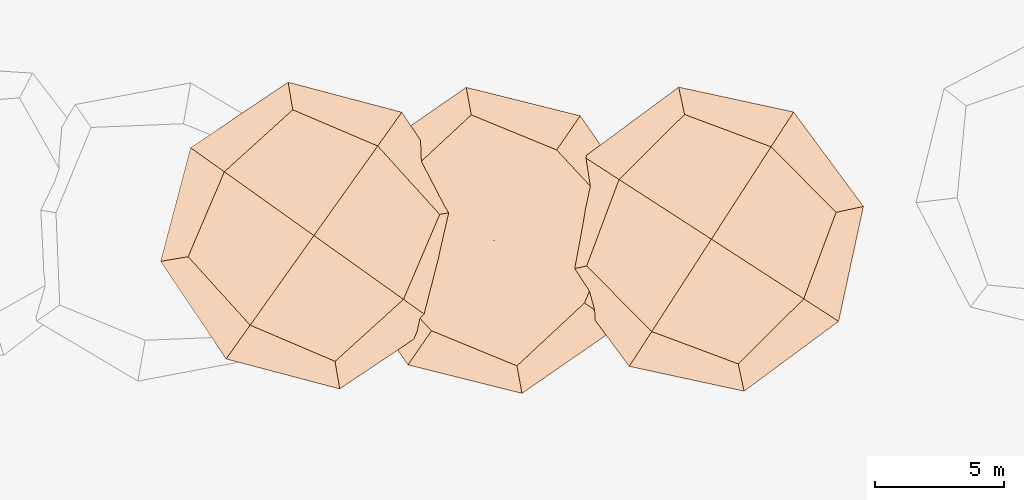
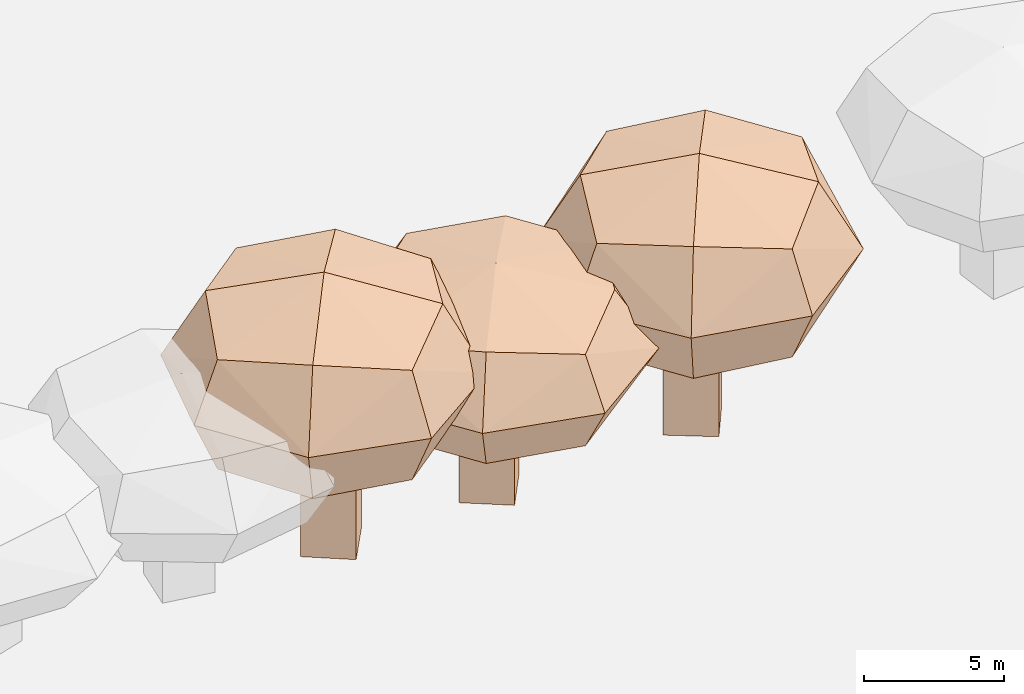
# Not in any storey, part 15 of 92: 3 geographic elements.
"""IFC4 model written with IfcOpenShell, lengths in metres."""

from ifc_helpers import new_model, si_unit, origin_with_axes, place, context, subcontext, project, spatial, triangles, material, element, save


model = new_model("IFC4")

# Units and contexts
model_context = context("Model", 3, precision=1e-05, world=origin_with_axes())
body_context = subcontext(model_context, "Body", "Model", "MODEL_VIEW")
ifc_project = project(units=[si_unit("VOLUMEUNIT", "CUBIC_METRE"), si_unit("LENGTHUNIT", "METRE"), si_unit("AREAUNIT", "SQUARE_METRE")], contexts=[model_context])

# Site
site_placement = place(None, origin_with_axes())
site = spatial("IfcSite", under=ifc_project, at=site_placement)

# Geographic elements
ifc_material = material(Name="tree")
geographic_element_1_placement = place(site_placement, origin_with_axes())
element("IfcGeographicElement", 1, at=geographic_element_1_placement, inside=site, material=ifc_material, Name="cw_instances_tree_206", context=body_context, shape_type="Tessellation", body=[
    triangles([(22.09761152949541, -637.1712850246641, 5.7020930998837915), (22.09761152949541, -637.1712850246641, 5.7020930998837915), (22.09761152949541, -637.1712850246641, 5.7020930998837915), (22.09761152949541, -637.1712850246641, 0.0), (22.09761152949541, -637.1712850246641, 0.0), (22.09761152949541, -637.1712850246641, 0.0), (23.235551606121536, -635.5265685196068, 5.7020930998837915), (23.235551606121536, -635.5265685196068, 5.7020930998837915), (23.235551606121536, -635.5265685196068, 5.7020930998837915), (23.235551606121536, -635.5265685196068, 0.0), (23.235551606121536, -635.5265685196068, 0.0), (23.235551606121536, -635.5265685196068, 0.0), (23.74232803455278, -638.3092251012903, 5.7020930998837915), (23.74232803455278, -638.3092251012903, 5.7020930998837915), (23.74232803455278, -638.3092251012903, 5.7020930998837915), (23.74232803455278, -638.3092251012903, 0.0), (23.74232803455278, -638.3092251012903, 0.0), (23.74232803455278, -638.3092251012903, 0.0), (24.880268111178907, -636.664508596233, 5.7020930998837915), (24.880268111178907, -636.664508596233, 5.7020930998837915), (24.880268111178907, -636.664508596233, 5.7020930998837915), (24.880268111178907, -636.664508596233, 0.0), (24.880268111178907, -636.664508596233, 0.0), (24.880268111178907, -636.664508596233, 0.0), (18.82385095888535, -637.9462855560657, 8.493639587729344), (18.82385095888535, -637.9462855560657, 8.493639587729344), (18.82385095888535, -637.9462855560657, 8.493639587729344), (18.82385095888535, -637.9462855560657, 8.493639587729344), (18.82385095888535, -637.9462855560657, 8.493639587729344), (18.82385095888535, -637.9462855560657, 8.493639587729344), (18.823850488413754, -637.9462858142449, 4.502174577469306), (18.823850488413754, -637.9462858142449, 4.502174577469306), (18.823850488413754, -637.9462858142449, 4.502174577469306), (18.823850488413754, -637.9462858142449, 4.502174577469306), (18.823850488413754, -637.9462858142449, 4.502174577469306), (18.823850488413754, -637.9462858142449, 4.502174577469306), (22.80664007953085, -632.1897790251504, 8.493639587729344), (22.80664007953085, -632.1897790251504, 8.493639587729344), (22.80664007953085, -632.1897790251504, 8.493639587729344), (22.80664007953085, -632.1897790251504, 8.493639587729344), (22.80664007953085, -632.1897790251504, 8.493639587729344), (22.80664007953085, -632.1897790251504, 8.493639587729344), (22.80664007953085, -632.1897790251504, 4.502174577469306), (22.80664007953085, -632.1897790251504, 4.502174577469306), (22.80664007953085, -632.1897790251504, 4.502174577469306), (22.80664007953085, -632.1897790251504, 4.502174577469306), (22.80664007953085, -632.1897790251504, 4.502174577469306), (22.80664007953085, -632.1897790251504, 4.502174577469306), (24.580357869606164, -641.9290758150205, 8.493639587729344), (24.580357869606164, -641.9290758150205, 8.493639587729344), (24.580357869606164, -641.9290758150205, 8.493639587729344), (24.580357869606164, -641.9290758150205, 8.493639587729344), (24.580357869606164, -641.9290758150205, 8.493639587729344), (24.580357869606164, -641.9290758150205, 8.493639587729344), (24.580357474874205, -641.9290755419148, 4.502174577469306), (24.580357474874205, -641.9290755419148, 4.502174577469306), (24.580357474874205, -641.9290755419148, 4.502174577469306), (24.580357474874205, -641.9290755419148, 4.502174577469306), (24.580357474874205, -641.9290755419148, 4.502174577469306), (24.580357474874205, -641.9290755419148, 4.502174577469306), (28.56314759727607, -636.17256882856, 8.493639587729344), (28.56314759727607, -636.17256882856, 8.493639587729344), (28.56314759727607, -636.17256882856, 8.493639587729344), (28.56314759727607, -636.17256882856, 8.493639587729344), (28.56314759727607, -636.17256882856, 8.493639587729344), (28.56314759727607, -636.17256882856, 8.493639587729344), (28.56314746072326, -636.172569025926, 4.502174577469306), (28.56314746072326, -636.172569025926, 4.502174577469306), (28.56314746072326, -636.172569025926, 4.502174577469306), (28.56314746072326, -636.172569025926, 4.502174577469306), (28.56314746072326, -636.172569025926, 4.502174577469306), (28.56314746072326, -636.172569025926, 4.502174577469306), (27.202480896920196, -639.4872080590724, 4.064838778889199), (27.202480896920196, -639.4872080590724, 4.064838778889199), (27.202480896920196, -639.4872080590724, 4.064838778889199), (27.202480896920196, -639.4872080590724, 4.064838778889199), (21.26571853147297, -640.5684087605208, 4.064838778889199), (21.26571853147297, -640.5684087605208, 4.064838778889199), (21.26571853147297, -640.5684087605208, 4.064838778889199), (21.26571853147297, -640.5684087605208, 4.064838778889199), (17.756737101223155, -638.1406282978454, 6.497907424724931), (17.756737101223155, -638.1406282978454, 6.497907424724931), (17.756737101223155, -638.1406282978454, 6.497907424724931), (17.756737101223155, -638.1406282978454, 6.497907424724931), (29.63026137097505, -635.9782266123755, 6.497907424724931), (29.63026137097505, -635.9782266123755, 6.497907424724931), (29.63026137097505, -635.9782266123755, 6.497907424724931), (29.63026137097505, -635.9782266123755, 6.497907424724931), (22.6122979473095, -631.1226647258565, 6.497907424724931), (22.6122979473095, -631.1226647258565, 6.497907424724931), (22.6122979473095, -631.1226647258565, 6.497907424724931), (22.6122979473095, -631.1226647258565, 6.497907424724931), (24.77470001106428, -642.9961892573345, 6.497907424724931), (24.77470001106428, -642.9961892573345, 6.497907424724931), (24.77470001106428, -642.9961892573345, 6.497907424724931), (24.77470001106428, -642.9961892573345, 6.497907424724931), (26.121279764067694, -633.5504454559477, 8.930975044183842), (26.121279764067694, -633.5504454559477, 8.930975044183842), (26.121279764067694, -633.5504454559477, 8.930975044183842), (26.121279764067694, -633.5504454559477, 8.930975044183842), (20.184517148941726, -634.6316466412976, 8.930976384175802), (20.184517148941726, -634.6316466412976, 8.930976384175802), (20.184517148941726, -634.6316466412976, 8.930976384175802), (20.184517148941726, -634.6316466412976, 8.930976384175802), (26.121279537769688, -633.5504458709047, 4.064838778889199), (26.121279537769688, -633.5504458709047, 4.064838778889199), (26.121279537769688, -633.5504458709047, 4.064838778889199), (26.121279537769688, -633.5504458709047, 4.064838778889199), (27.202480874161395, -639.4872080919667, 8.930975044183842), (27.202480874161395, -639.4872080919667, 8.930975044183842), (27.202480874161395, -639.4872080919667, 8.930975044183842), (27.202480874161395, -639.4872080919667, 8.930975044183842), (21.265718506802223, -640.5684087434518, 8.930976384175802), (21.265718506802223, -640.5684087434518, 8.930976384175802), (21.265718506802223, -640.5684087434518, 8.930976384175802), (21.265718506802223, -640.5684087434518, 8.930976384175802), (20.18451756958831, -634.631646859372, 4.064838778889199), (20.18451756958831, -634.631646859372, 4.064838778889199), (20.18451756958831, -634.631646859372, 4.064838778889199), (20.18451756958831, -634.631646859372, 4.064838778889199), (23.69349899166068, -637.0594274744716, 9.848767440028226), (23.69349899166068, -637.0594274744716, 9.848767440028226), (23.69349899166068, -637.0594274744716, 9.848767440028226), (23.69349899166068, -637.0594274744716, 9.848767440028226), (23.69349899166068, -637.0594274744716, 9.848767440028226), (23.69349899166068, -637.0594274744716, 9.848767440028226), (23.69349899166068, -637.0594274744716, 9.848767440028226), (23.69349899166068, -637.0594274744716, 9.848767440028226), (27.037075525865962, -632.2268042241907, 6.497907424724931), (27.037075525865962, -632.2268042241907, 6.497907424724931), (27.037075525865962, -632.2268042241907, 6.497907424724931), (27.037075525865962, -632.2268042241907, 6.497907424724931), (27.037075525865962, -632.2268042241907, 6.497907424724931), (27.037075525865962, -632.2268042241907, 6.497907424724931), (27.037075525865962, -632.2268042241907, 6.497907424724931), (27.037075525865962, -632.2268042241907, 6.497907424724931), (28.526122111608213, -640.4030038455414, 6.497907424724931), (28.526122111608213, -640.4030038455414, 6.497907424724931), (28.526122111608213, -640.4030038455414, 6.497907424724931), (28.526122111608213, -640.4030038455414, 6.497907424724931), (28.526122111608213, -640.4030038455414, 6.497907424724931), (28.526122111608213, -640.4030038455414, 6.497907424724931), (28.526122111608213, -640.4030038455414, 6.497907424724931), (28.526122111608213, -640.4030038455414, 6.497907424724931), (23.693498876530523, -637.0594273948159, 3.147048065162381), (23.693498876530523, -637.0594273948159, 3.147048065162381), (23.693498876530523, -637.0594273948159, 3.147048065162381), (23.693498876530523, -637.0594273948159, 3.147048065162381), (23.693498876530523, -637.0594273948159, 3.147048065162381), (23.693498876530523, -637.0594273948159, 3.147048065162381), (23.693498876530523, -637.0594273948159, 3.147048065162381), (23.693498876530523, -637.0594273948159, 3.147048065162381), (18.860876263865084, -633.7158512044803, 6.497907424724931), (18.860876263865084, -633.7158512044803, 6.497907424724931), (18.860876263865084, -633.7158512044803, 6.497907424724931), (18.860876263865084, -633.7158512044803, 6.497907424724931), (18.860876263865084, -633.7158512044803, 6.497907424724931), (18.860876263865084, -633.7158512044803, 6.497907424724931), (18.860876263865084, -633.7158512044803, 6.497907424724931), (18.860876263865084, -633.7158512044803, 6.497907424724931), (20.349922537686997, -641.8920504154585, 6.497907424724931), (20.349922537686997, -641.8920504154585, 6.497907424724931), (20.349922537686997, -641.8920504154585, 6.497907424724931), (20.349922537686997, -641.8920504154585, 6.497907424724931), (20.349922537686997, -641.8920504154585, 6.497907424724931), (20.349922537686997, -641.8920504154585, 6.497907424724931), (20.349922537686997, -641.8920504154585, 6.497907424724931), (20.349922537686997, -641.8920504154585, 6.497907424724931)], [[15, 8, 2], [7, 24, 11], [19, 16, 22], [4, 23, 17], [3, 12, 6], [14, 5, 18], [26, 127, 101], [54, 123, 114], [124, 66, 98], [128, 38, 102], [45, 133, 108], [40, 135, 89], [130, 63, 88], [131, 70, 105], [68, 141, 73], [61, 140, 86], [137, 49, 93], [142, 56, 74], [59, 145, 75], [31, 149, 79], [150, 43, 107], [146, 71, 76], [35, 154, 120], [30, 157, 83], [158, 42, 91], [153, 47, 119], [58, 164, 77], [51, 162, 96], [167, 28, 81], [165, 33, 80], [15, 21, 8], [7, 20, 24], [19, 13, 16], [4, 10, 23], [3, 9, 12], [14, 1, 5], [25, 115, 126], [53, 111, 121], [122, 112, 65], [125, 99, 37], [46, 90, 136], [39, 100, 134], [132, 97, 64], [129, 87, 69], [67, 85, 138], [62, 110, 144], [143, 109, 50], [139, 94, 55], [60, 78, 147], [32, 117, 151], [152, 118, 44], [148, 106, 72], [36, 84, 160], [29, 104, 156], [155, 103, 41], [159, 92, 48], [57, 95, 161], [52, 113, 163], [166, 116, 27], [168, 82, 34]], closed=True),
])
geographic_element_2_placement = place(site_placement, origin_with_axes())
element("IfcGeographicElement", 2, at=geographic_element_2_placement, inside=site, material=ifc_material, Name="cw_instances_tree_229", context=body_context, shape_type="Tessellation", body=[
    triangles([(30.534169717315095, -637.1753563135563, 6.7440406053230895), (30.534169717315095, -637.1753563135563, 6.7440406053230895), (30.534169717315095, -637.1753563135563, 6.7440406053230895), (30.534169717315095, -637.1753563135563, 0.0), (30.534169717315095, -637.1753563135563, 0.0), (30.534169717315095, -637.1753563135563, 0.0), (31.619404262986556, -635.4953962006723, 6.7440406053230895), (31.619404262986556, -635.4953962006723, 6.7440406053230895), (31.619404262986556, -635.4953962006723, 6.7440406053230895), (31.619404262986556, -635.4953962006723, 0.0), (31.619404262986556, -635.4953962006723, 0.0), (31.619404262986556, -635.4953962006723, 0.0), (32.214129830199106, -638.2605908592278, 6.7440406053230895), (32.214129830199106, -638.2605908592278, 6.7440406053230895), (32.214129830199106, -638.2605908592278, 6.7440406053230895), (32.214129830199106, -638.2605908592278, 0.0), (32.214129830199106, -638.2605908592278, 0.0), (32.214129830199106, -638.2605908592278, 0.0), (33.29936437587057, -636.5806307463438, 6.7440406053230895), (33.29936437587057, -636.5806307463438, 6.7440406053230895), (33.29936437587057, -636.5806307463438, 6.7440406053230895), (33.29936437587057, -636.5806307463438, 0.0), (33.29936437587057, -636.5806307463438, 0.0), (33.29936437587057, -636.5806307463438, 0.0), (27.286619933827538, -638.0537380649172, 10.045688357454871), (27.286619933827538, -638.0537380649172, 10.045688357454871), (27.286619933827538, -638.0537380649172, 10.045688357454871), (27.286619933827538, -638.0537380649172, 10.045688357454871), (27.286619933827538, -638.0537380649172, 10.045688357454871), (27.286619933827538, -638.0537380649172, 10.045688357454871), (27.286619471776035, -638.0537383378795, 5.324860122561857), (27.286619471776035, -638.0537383378795, 5.324860122561857), (27.286619471776035, -638.0537383378795, 5.324860122561857), (27.286619471776035, -638.0537383378795, 5.324860122561857), (27.286619471776035, -638.0537383378795, 5.324860122561857), (27.286619471776035, -638.0537383378795, 5.324860122561857), (31.084939735911593, -632.1738789423617, 10.045688357454871), (31.084939735911593, -632.1738789423617, 10.045688357454871), (31.084939735911593, -632.1738789423617, 10.045688357454871), (31.084939735911593, -632.1738789423617, 10.045688357454871), (31.084939735911593, -632.1738789423617, 10.045688357454871), (31.084939735911593, -632.1738789423617, 10.045688357454871), (31.084939735911593, -632.1738789423617, 5.324860122561857), (31.084939735911593, -632.1738789423617, 5.324860122561857), (31.084939735911593, -632.1738789423617, 5.324860122561857), (31.084939735911593, -632.1738789423617, 5.324860122561857), (31.084939735911593, -632.1738789423617, 5.324860122561857), (31.084939735911593, -632.1738789423617, 5.324860122561857), (33.166479472079445, -641.8520589926994, 10.045688357454871), (33.166479472079445, -641.8520589926994, 10.045688357454871), (33.166479472079445, -641.8520589926994, 10.045688357454871), (33.166479472079445, -641.8520589926994, 10.045688357454871), (33.166479472079445, -641.8520589926994, 10.045688357454871), (33.166479472079445, -641.8520589926994, 10.045688357454871), (33.16647906888902, -641.8520587322432, 5.324860122561857), (33.16647906888902, -641.8520587322432, 5.324860122561857), (33.16647906888902, -641.8520587322432, 5.324860122561857), (33.16647906888902, -641.8520587322432, 5.324860122561857), (33.16647906888902, -641.8520587322432, 5.324860122561857), (33.16647906888902, -641.8520587322432, 5.324860122561857), (36.96479986644315, -635.9721993955865, 10.045688357454871), (36.96479986644315, -635.9721993955865, 10.045688357454871), (36.96479986644315, -635.9721993955865, 10.045688357454871), (36.96479986644315, -635.9721993955865, 10.045688357454871), (36.96479986644315, -635.9721993955865, 10.045688357454871), (36.96479986644315, -635.9721993955865, 10.045688357454871), (36.96479973621501, -635.9721995971817, 5.324860122561857), (36.96479973621501, -635.9721995971817, 5.324860122561857), (36.96479973621501, -635.9721995971817, 5.324860122561857), (36.96479973621501, -635.9721995971817, 5.324860122561857), (36.96479973621501, -635.9721995971817, 5.324860122561857), (36.96479973621501, -635.9721995971817, 5.324860122561857), (35.70988331399176, -639.328303020967, 4.807609644163714), (35.70988331399176, -639.328303020967, 4.807609644163714), (35.70988331399176, -639.328303020967, 4.807609644163714), (35.70988331399176, -639.328303020967, 4.807609644163714), (29.81037572790661, -640.5971420896936, 4.807609644163714), (29.81037572790661, -640.5971420896936, 4.807609644163714), (29.81037572790661, -640.5971420896936, 4.807609644163714), (29.81037572790661, -640.5971420896936, 4.807609644163714), (26.22620251535363, -638.2818081968816, 7.685274644650824), (26.22620251535363, -638.2818081968816, 7.685274644650824), (26.22620251535363, -638.2818081968816, 7.685274644650824), (26.22620251535363, -638.2818081968816, 7.685274644650824), (38.025217217656184, -635.7441297916145, 7.685274644650824), (38.025217217656184, -635.7441297916145, 7.685274644650824), (38.025217217656184, -635.7441297916145, 7.685274644650824), (38.025217217656184, -635.7441297916145, 7.685274644650824), (30.856870199200486, -631.1134610631563, 7.685274644650824), (30.856870199200486, -631.1134610631563, 7.685274644650824), (30.856870199200486, -631.1134610631563, 7.685274644650824), (30.856870199200486, -631.1134610631563, 7.685274644650824), (33.39454899085839, -642.9124760150628, 7.685274644650824), (33.39454899085839, -642.9124760150628, 7.685274644650824), (33.39454899085839, -642.9124760150628, 7.685274644650824), (33.39454899085839, -642.9124760150628, 7.685274644650824), (34.44104380654409, -633.4287952109985, 10.56293843121055), (34.44104380654409, -633.4287952109985, 10.56293843121055), (34.44104380654409, -633.4287952109985, 10.56293843121055), (34.44104380654409, -633.4287952109985, 10.56293843121055), (28.541535986244217, -634.6976347712975, 10.562940016060189), (28.541535986244217, -634.6976347712975, 10.562940016060189), (28.541535986244217, -634.6976347712975, 10.562940016060189), (28.541535986244217, -634.6976347712975, 10.562940016060189), (34.44104359351297, -633.42879563292, 4.807609644163714), (34.44104359351297, -633.42879563292, 4.807609644163714), (34.44104359351297, -633.42879563292, 4.807609644163714), (34.44104359351297, -633.42879563292, 4.807609644163714), (35.70988329228707, -639.3283030545663, 10.56293843121055), (35.70988329228707, -639.3283030545663, 10.56293843121055), (35.70988329228707, -639.3283030545663, 10.56293843121055), (35.70988329228707, -639.3283030545663, 10.56293843121055), (29.810375702707205, -640.5971420734152, 10.562940016060189), (29.810375702707205, -640.5971420734152, 10.562940016060189), (29.810375702707205, -640.5971420734152, 10.562940016060189), (29.810375702707205, -640.5971420734152, 10.562940016060189), (28.54153641359188, -634.6976349759288, 4.807609644163714), (28.54153641359188, -634.6976349759288, 4.807609644163714), (28.54153641359188, -634.6976349759288, 4.807609644163714), (28.54153641359188, -634.6976349759288, 4.807609644163714), (32.125709622803015, -637.0129690213477, 11.648439680735473), (32.125709622803015, -637.0129690213477, 11.648439680735473), (32.125709622803015, -637.0129690213477, 11.648439680735473), (32.125709622803015, -637.0129690213477, 11.648439680735473), (32.125709622803015, -637.0129690213477, 11.648439680735473), (32.125709622803015, -637.0129690213477, 11.648439680735473), (32.125709622803015, -637.0129690213477, 11.648439680735473), (32.125709622803015, -637.0129690213477, 11.648439680735473), (35.31442300980553, -632.076790493904, 7.685274644650824), (35.31442300980553, -632.076790493904, 7.685274644650824), (35.31442300980553, -632.076790493904, 7.685274644650824), (35.31442300980553, -632.076790493904, 7.685274644650824), (35.31442300980553, -632.076790493904, 7.685274644650824), (35.31442300980553, -632.076790493904, 7.685274644650824), (35.31442300980553, -632.076790493904, 7.685274644650824), (35.31442300980553, -632.076790493904, 7.685274644650824), (37.061888014807664, -640.2016822494279, 7.685274644650824), (37.061888014807664, -640.2016822494279, 7.685274644650824), (37.061888014807664, -640.2016822494279, 7.685274644650824), (37.061888014807664, -640.2016822494279, 7.685274644650824), (37.061888014807664, -640.2016822494279, 7.685274644650824), (37.061888014807664, -640.2016822494279, 7.685274644650824), (37.061888014807664, -640.2016822494279, 7.685274644650824), (37.061888014807664, -640.2016822494279, 7.685274644650824), (32.12570950520581, -637.0129689453812, 3.722110384130891), (32.12570950520581, -637.0129689453812, 3.722110384130891), (32.12570950520581, -637.0129689453812, 3.722110384130891), (32.12570950520581, -637.0129689453812, 3.722110384130891), (32.12570950520581, -637.0129689453812, 3.722110384130891), (32.12570950520581, -637.0129689453812, 3.722110384130891), (32.12570950520581, -637.0129689453812, 3.722110384130891), (32.12570950520581, -637.0129689453812, 3.722110384130891), (27.18953162595721, -633.8242558818648, 7.685274644650824), (27.18953162595721, -633.8242558818648, 7.685274644650824), (27.18953162595721, -633.8242558818648, 7.685274644650824), (27.18953162595721, -633.8242558818648, 7.685274644650824), (27.18953162595721, -633.8242558818648, 7.685274644650824), (27.18953162595721, -633.8242558818648, 7.685274644650824), (27.18953162595721, -633.8242558818648, 7.685274644650824), (27.18953162595721, -633.8242558818648, 7.685274644650824), (28.93699630618788, -641.9491472371094, 7.685274644650824), (28.93699630618788, -641.9491472371094, 7.685274644650824), (28.93699630618788, -641.9491472371094, 7.685274644650824), (28.93699630618788, -641.9491472371094, 7.685274644650824), (28.93699630618788, -641.9491472371094, 7.685274644650824), (28.93699630618788, -641.9491472371094, 7.685274644650824), (28.93699630618788, -641.9491472371094, 7.685274644650824), (28.93699630618788, -641.9491472371094, 7.685274644650824)], [[15, 8, 2], [7, 24, 11], [19, 16, 22], [4, 23, 17], [3, 12, 6], [14, 5, 18], [26, 127, 101], [54, 123, 114], [124, 66, 98], [128, 38, 102], [45, 133, 108], [40, 135, 89], [130, 63, 88], [131, 70, 105], [68, 141, 73], [61, 140, 86], [137, 49, 93], [142, 56, 74], [59, 145, 75], [31, 149, 79], [150, 43, 107], [146, 71, 76], [35, 154, 120], [30, 157, 83], [158, 42, 91], [153, 47, 119], [58, 164, 77], [51, 162, 96], [167, 28, 81], [165, 33, 80], [15, 21, 8], [7, 20, 24], [19, 13, 16], [4, 10, 23], [3, 9, 12], [14, 1, 5], [25, 115, 126], [53, 111, 121], [122, 112, 65], [125, 99, 37], [46, 90, 136], [39, 100, 134], [132, 97, 64], [129, 87, 69], [67, 85, 138], [62, 110, 144], [143, 109, 50], [139, 94, 55], [60, 78, 147], [32, 117, 151], [152, 118, 44], [148, 106, 72], [36, 84, 160], [29, 104, 156], [155, 103, 41], [159, 92, 48], [57, 95, 161], [52, 113, 163], [166, 116, 27], [168, 82, 34]], closed=True),
])
geographic_element_3_placement = place(site_placement, origin_with_axes())
element("IfcGeographicElement", 3, at=geographic_element_3_placement, inside=site, material=ifc_material, Name="cw_instances_tree_231", context=body_context, shape_type="Tessellation", body=[
    triangles([(18.298752638097486, -636.7832801582259, 6.821645885434237), (18.298752638097486, -636.7832801582259, 6.821645885434237), (18.298752638097486, -636.7832801582259, 6.821645885434237), (18.298752638097486, -636.7832801582259, 0.0), (18.298752638097486, -636.7832801582259, 0.0), (18.298752638097486, -636.7832801582259, 0.0), (17.13872336958333, -638.41249226725, 6.821645885434237), (17.13872336958333, -638.41249226725, 6.821645885434237), (17.13872336958333, -638.41249226725, 6.821645885434237), (17.13872336958333, -638.41249226725, 0.0), (17.13872336958333, -638.41249226725, 0.0), (17.13872336958333, -638.41249226725, 0.0), (16.66954052907346, -635.6232508897117, 6.821645885434237), (16.66954052907346, -635.6232508897117, 6.821645885434237), (16.66954052907346, -635.6232508897117, 6.821645885434237), (16.66954052907346, -635.6232508897117, 0.0), (16.66954052907346, -635.6232508897117, 0.0), (16.66954052907346, -635.6232508897117, 0.0), (15.509511260559306, -637.2524629987357, 6.821645885434237), (15.509511260559306, -637.2524629987357, 6.821645885434237), (15.509511260559306, -637.2524629987357, 6.821645885434237), (15.509511260559306, -637.2524629987357, 0.0), (15.509511260559306, -637.2524629987357, 0.0), (15.509511260559306, -637.2524629987357, 0.0), (21.582672545092585, -636.052524288051, 10.161286483936234), (21.582672545092585, -636.052524288051, 10.161286483936234), (21.582672545092585, -636.052524288051, 10.161286483936234), (21.582672545092585, -636.052524288051, 10.161286483936234), (21.582672545092585, -636.052524288051, 10.161286483936234), (21.582672545092585, -636.052524288051, 10.161286483936234), (21.58267301900506, -636.0525240362435, 5.386134555138363), (21.58267301900506, -636.0525240362435, 5.386134555138363), (21.58267301900506, -636.0525240362435, 5.386134555138363), (21.58267301900506, -636.0525240362435, 5.386134555138363), (21.58267301900506, -636.0525240362435, 5.386134555138363), (21.58267301900506, -636.0525240362435, 5.386134555138363), (17.522571269422933, -641.7547654484465, 10.161286483936234), (17.522571269422933, -641.7547654484465, 10.161286483936234), (17.522571269422933, -641.7547654484465, 10.161286483936234), (17.522571269422933, -641.7547654484465, 10.161286483936234), (17.522571269422933, -641.7547654484465, 10.161286483936234), (17.522571269422933, -641.7547654484465, 10.161286483936234), (17.522571269422933, -641.7547654484465, 5.386134555138363), (17.522571269422933, -641.7547654484465, 5.386134555138363), (17.522571269422933, -641.7547654484465, 5.386134555138363), (17.522571269422933, -641.7547654484465, 5.386134555138363), (17.522571269422933, -641.7547654484465, 5.386134555138363), (17.522571269422933, -641.7547654484465, 5.386134555138363), (15.880431020285815, -631.9924218690509, 10.161286483936234), (15.880431020285815, -631.9924218690509, 10.161286483936234), (15.880431020285815, -631.9924218690509, 10.161286483936234), (15.880431020285815, -631.9924218690509, 10.161286483936234), (15.880431020285815, -631.9924218690509, 10.161286483936234), (15.880431020285815, -631.9924218690509, 10.161286483936234), (15.88043141129672, -631.9924221474579, 5.386134555138363), (15.88043141129672, -631.9924221474579, 5.386134555138363), (15.88043141129672, -631.9924221474579, 5.386134555138363), (15.88043141129672, -631.9924221474579, 5.386134555138363), (15.88043141129672, -631.9924221474579, 5.386134555138363), (15.88043141129672, -631.9924221474579, 5.386134555138363), (11.820329131500175, -637.6946634767593, 10.161286483936234), (11.820329131500175, -637.6946634767593, 10.161286483936234), (11.820329131500175, -637.6946634767593, 10.161286483936234), (11.820329131500175, -637.6946634767593, 10.161286483936234), (11.820329131500175, -637.6946634767593, 10.161286483936234), (11.820329131500175, -637.6946634767593, 10.161286483936234), (11.820329270703688, -637.6946632812538, 5.386134555138363), (11.820329270703688, -637.6946632812538, 5.386134555138363), (11.820329270703688, -637.6946632812538, 5.386134555138363), (11.820329270703688, -637.6946632812538, 5.386134555138363), (11.820329270703688, -637.6946632812538, 5.386134555138363), (11.820329270703688, -637.6946632812538, 5.386134555138363), (13.225597653701907, -634.398686007416, 4.862931952396244), (13.225597653701907, -634.398686007416, 4.862931952396244), (13.225597653701907, -634.398686007416, 4.862931952396244), (13.225597653701907, -634.398686007416, 4.862931952396244), (19.176408592461435, -633.3976907468162, 4.862931952396244), (19.176408592461435, -633.3976907468162, 4.862931952396244), (19.176408592461435, -633.3976907468162, 4.862931952396244), (19.176408592461435, -633.3976907468162, 4.862931952396244), (22.652311593935867, -635.8725982152133, 7.773710928836076), (22.652311593935867, -635.8725982152133, 7.773710928836076), (22.652311593935867, -635.8725982152133, 7.773710928836076), (22.652311593935867, -635.8725982152133, 7.773710928836076), (10.750690173704523, -637.8745890251826, 7.773710928836076), (10.750690173704523, -637.8745890251826, 7.773710928836076), (10.750690173704523, -637.8745890251826, 7.773710928836076), (10.750690173704523, -637.8745890251826, 7.773710928836076), (17.702496726798625, -642.8244049306563, 7.773710928836076), (17.702496726798625, -642.8244049306563, 7.773710928836076), (17.702496726798625, -642.8244049306563, 7.773710928836076), (17.702496726798625, -642.8244049306563, 7.773710928836076), (15.700505542110639, -630.9227832436183, 7.773710928836076), (15.700505542110639, -630.9227832436183, 7.773710928836076), (15.700505542110639, -630.9227832436183, 7.773710928836076), (15.700505542110639, -630.9227832436183, 7.773710928836076), (14.226593342459346, -640.3494971896524, 10.684488677379573), (14.226593342459346, -640.3494971896524, 10.684488677379573), (14.226593342459346, -640.3494971896524, 10.684488677379573), (14.226593342459346, -640.3494971896524, 10.684488677379573), (20.177404537404353, -639.3485014485643, 10.684490280466454), (20.177404537404353, -639.3485014485643, 10.684490280466454), (20.177404537404353, -639.3485014485643, 10.684490280466454), (20.177404537404353, -639.3485014485643, 10.684490280466454), (14.226593574335922, -640.3494967777868, 4.862931952396244), (14.226593574335922, -640.3494967777868, 4.862931952396244), (14.226593574335922, -640.3494967777868, 4.862931952396244), (14.226593574335922, -640.3494967777868, 4.862931952396244), (13.225597676902494, -634.3986859748318, 10.684488677379573), (13.225597676902494, -634.3986859748318, 10.684488677379573), (13.225597676902494, -634.3986859748318, 10.684488677379573), (13.225597676902494, -634.3986859748318, 10.684488677379573), (19.176408616899614, -633.3976907642167, 10.684490280466454), (19.176408616899614, -633.3976907642167, 10.684490280466454), (19.176408616899614, -633.3976907642167, 10.684490280466454), (19.176408616899614, -633.3976907642167, 10.684490280466454), (20.177404119738625, -639.3485012248339, 4.862931952396244), (20.177404119738625, -639.3485012248339, 4.862931952396244), (20.177404119738625, -639.3485012248339, 4.862931952396244), (20.177404119738625, -639.3485012248339, 4.862931952396244), (16.701501128497615, -636.8735936041368, 11.782481048097313), (16.701501128497615, -636.8735936041368, 11.782481048097313), (16.701501128497615, -636.8735936041368, 11.782481048097313), (16.701501128497615, -636.8735936041368, 11.782481048097313), (16.701501128497615, -636.8735936041368, 11.782481048097313), (16.701501128497615, -636.8735936041368, 11.782481048097313), (16.701501128497615, -636.8735936041368, 11.782481048097313), (16.701501128497615, -636.8735936041368, 11.782481048097313), (13.293020556432719, -641.660660734343, 7.773710928836076), (13.293020556432719, -641.660660734343, 7.773710928836076), (13.293020556432719, -641.660660734343, 7.773710928836076), (13.293020556432719, -641.660660734343, 7.773710928836076), (13.293020556432719, -641.660660734343, 7.773710928836076), (13.293020556432719, -641.660660734343, 7.773710928836076), (13.293020556432719, -641.660660734343, 7.773710928836076), (13.293020556432719, -641.660660734343, 7.773710928836076), (11.914434126411734, -633.4651131969512, 7.773710928836076), (11.914434126411734, -633.4651131969512, 7.773710928836076), (11.914434126411734, -633.4651131969512, 7.773710928836076), (11.914434126411734, -633.4651131969512, 7.773710928836076), (11.914434126411734, -633.4651131969512, 7.773710928836076), (11.914434126411734, -633.4651131969512, 7.773710928836076), (11.914434126411734, -633.4651131969512, 7.773710928836076), (11.914434126411734, -633.4651131969512, 7.773710928836076), (16.70150124254246, -636.8735936853388, 3.764941594064161), (16.70150124254246, -636.8735936853388, 3.764941594064161), (16.70150124254246, -636.8735936853388, 3.764941594064161), (16.70150124254246, -636.8735936853388, 3.764941594064161), (16.70150124254246, -636.8735936853388, 3.764941594064161), (16.70150124254246, -636.8735936853388, 3.764941594064161), (16.70150124254246, -636.8735936853388, 3.764941594064161), (16.70150124254246, -636.8735936853388, 3.764941594064161), (21.48856773983114, -640.2820739049617, 7.773710928836076), (21.48856773983114, -640.2820739049617, 7.773710928836076), (21.48856773983114, -640.2820739049617, 7.773710928836076), (21.48856773983114, -640.2820739049617, 7.773710928836076), (21.48856773983114, -640.2820739049617, 7.773710928836076), (21.48856773983114, -640.2820739049617, 7.773710928836076), (21.48856773983114, -640.2820739049617, 7.773710928836076), (21.48856773983114, -640.2820739049617, 7.773710928836076), (20.109981616164784, -632.086526782114, 7.773710928836076), (20.109981616164784, -632.086526782114, 7.773710928836076), (20.109981616164784, -632.086526782114, 7.773710928836076), (20.109981616164784, -632.086526782114, 7.773710928836076), (20.109981616164784, -632.086526782114, 7.773710928836076), (20.109981616164784, -632.086526782114, 7.773710928836076), (20.109981616164784, -632.086526782114, 7.773710928836076), (20.109981616164784, -632.086526782114, 7.773710928836076)], [[15, 8, 2], [7, 24, 11], [19, 16, 22], [4, 23, 17], [3, 12, 6], [14, 5, 18], [26, 127, 101], [54, 123, 114], [124, 66, 98], [128, 38, 102], [45, 133, 108], [40, 135, 89], [130, 63, 88], [131, 70, 105], [68, 141, 73], [61, 140, 86], [137, 49, 93], [142, 56, 74], [59, 145, 75], [31, 149, 79], [150, 43, 107], [146, 71, 76], [35, 154, 120], [30, 157, 83], [158, 42, 91], [153, 47, 119], [58, 164, 77], [51, 162, 96], [167, 28, 81], [165, 33, 80], [15, 21, 8], [7, 20, 24], [19, 13, 16], [4, 10, 23], [3, 9, 12], [14, 1, 5], [25, 115, 126], [53, 111, 121], [122, 112, 65], [125, 99, 37], [46, 90, 136], [39, 100, 134], [132, 97, 64], [129, 87, 69], [67, 85, 138], [62, 110, 144], [143, 109, 50], [139, 94, 55], [60, 78, 147], [32, 117, 151], [152, 118, 44], [148, 106, 72], [36, 84, 160], [29, 104, 156], [155, 103, 41], [159, 92, 48], [57, 95, 161], [52, 113, 163], [166, 116, 27], [168, 82, 34]], closed=True),
])

save(model, "model.ifc")
